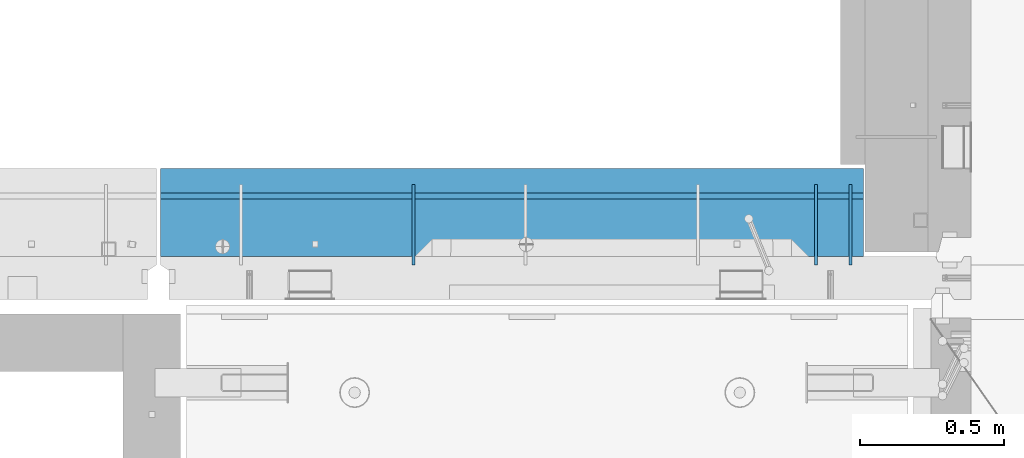
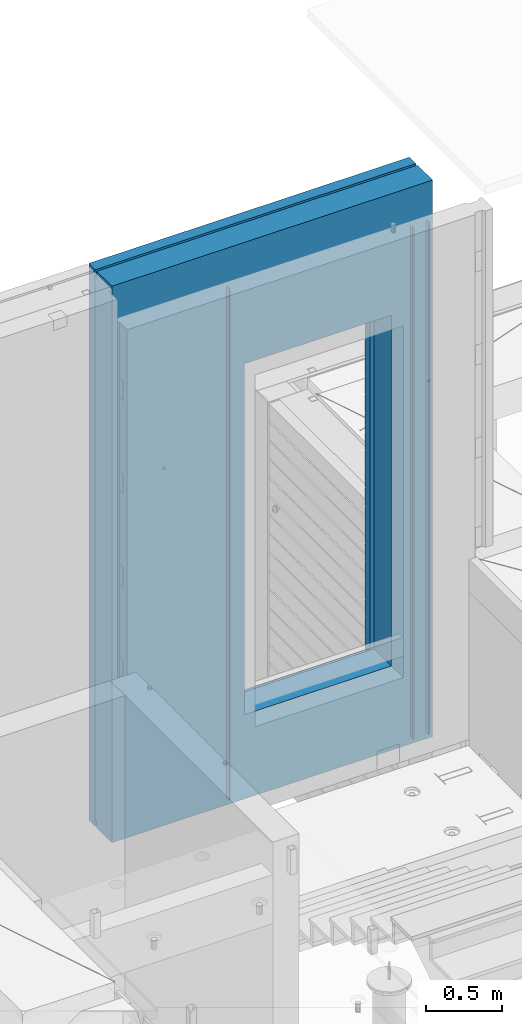
# One storey, part 240 of 352: 5 walls, 2 elements without a shape of their own.
"""IFC2X3 building model written with IfcOpenShell, lengths in millimetres."""

from ifc_helpers import new_model, si_unit, frame, origin_with_axes, place, context, subcontext, project, spatial, faceted_brep, material, type_object, element, aggregate, save


model = new_model("IFC2X3")

# Units and contexts
model_context = context("Model", 3, precision=1e-05, world=origin_with_axes())
body_context = subcontext(model_context, "Body", "Model", "MODEL_VIEW")
ifc_project = project(units=[si_unit("LENGTHUNIT", "METRE", prefix="MILLI"), si_unit("AREAUNIT", "SQUARE_METRE"), si_unit("VOLUMEUNIT", "CUBIC_METRE"), si_unit("MASSUNIT", "GRAM", prefix="KILO"), si_unit("TIMEUNIT", "SECOND"), si_unit("PLANEANGLEUNIT", "RADIAN"), si_unit("SOLIDANGLEUNIT", "STERADIAN"), si_unit("THERMODYNAMICTEMPERATUREUNIT", "DEGREE_CELSIUS"), si_unit("LUMINOUSINTENSITYUNIT", "LUMEN")], contexts=[model_context])

# Site, building, storey
site_placement = place(None, origin_with_axes())
site = spatial("IfcSite", under=ifc_project, at=site_placement, CompositionType="ELEMENT")
building_placement = place(site_placement, origin_with_axes())
building = spatial("IfcBuilding", under=site, at=building_placement, CompositionType="ELEMENT")
storey_placement = place(building_placement, origin_with_axes())
storey = spatial("IfcBuildingStorey", under=building, at=storey_placement, Name="6", CompositionType="ELEMENT", Elevation=0.0)

# Assemblies, walls
assembly_1_placement = place(storey_placement, origin_with_axes())
assembly_1 = element("IfcElementAssembly", 1, at=assembly_1_placement, inside=storey, AssemblyPlace="NOTDEFINED", PredefinedType="REINFORCEMENT_UNIT")
ifc_material_1 = material(Name="Undefined")
wall_type_1 = type_object("IfcWallType", PredefinedType="NOTDEFINED")
wall_1_placement = place(assembly_1_placement, frame((21990.0002441406, 20550.0, 100370.0), z_axis=(0.0, 0.0, 1.0), x_axis=(0.0, 1.0, 0.0)))
wall_1 = element("IfcWall", 2, at=wall_1_placement, type_object=wall_type_1, material=ifc_material_1, Name="(PD)", context=body_context, shape_type="Brep", body=[
    faceted_brep([(0.0, 5.0, -2060.0), (0.0, 5.0, 2060.0), (280.0, 5.0, 2060.0), (280.0, 5.0, -2060.0), (0.0, -5.0, 2060.0), (280.0, -5.0, 2060.0), (0.0, -5.0, -2060.0), (280.0, -5.0, -2060.0)], [[[0, 1, 2, 3]], [[1, 4, 5, 2]], [[4, 6, 7, 5]], [[6, 0, 3, 7]], [[5, 7, 3, 2]], [[6, 4, 1, 0]]]),
])
wall_2_placement = place(assembly_1_placement, frame((20470.0002441406, 20550.0, 100370.0), z_axis=(0.0, 0.0, 1.0), x_axis=(0.0, 1.0, 0.0)))
wall_2 = element("IfcWall", 3, at=wall_2_placement, type_object=wall_type_1, material=ifc_material_1, Name="(PD)", context=body_context, shape_type="Brep", body=[
    faceted_brep([(0.0, 5.0, -2060.0), (0.0, 5.0, 2060.0), (280.0, 5.0, 2060.0), (280.0, 5.0, -2060.0), (0.0, -5.0, 2060.0), (280.0, -5.0, 2060.0), (0.0, -5.0, -2060.0), (280.0, -5.0, -2060.0)], [[[0, 1, 2, 3]], [[1, 4, 5, 2]], [[4, 6, 7, 5]], [[6, 0, 3, 7]], [[5, 7, 3, 2]], [[6, 4, 1, 0]]]),
])
wall_3_placement = place(assembly_1_placement, frame((21870.0002441406, 20550.0, 100370.0), z_axis=(0.0, 0.0, 1.0), x_axis=(0.0, 1.0, 0.0)))
wall_3 = element("IfcWall", 4, at=wall_3_placement, type_object=wall_type_1, material=ifc_material_1, Name="(PD)", context=body_context, shape_type="Brep", body=[
    faceted_brep([(0.0, 5.0, -2060.0), (0.0, 5.0, 2060.0), (280.0, 5.0, 2060.0), (280.0, 5.0, -2060.0), (0.0, -5.0, 2060.0), (280.0, -5.0, 2060.0), (0.0, -5.0, -2060.0), (280.0, -5.0, -2060.0)], [[[0, 1, 2, 3]], [[1, 4, 5, 2]], [[4, 6, 7, 5]], [[6, 0, 3, 7]], [[5, 7, 3, 2]], [[6, 4, 1, 0]]]),
])
ifc_material_2 = material(Name="CONCRETE/C30/37")
wall_type_2 = type_object("IfcWallType", PredefinedType="NOTDEFINED")
wall_4_placement = place(assembly_1_placement, frame((19590.0, 20842.5, 100497.5), z_axis=(0.0, 0.0, 1.0), x_axis=(1.0, 0.0, 0.0)))
wall_4 = element("IfcWall", 5, at=wall_4_placement, type_object=wall_type_2, material=ifc_material_2, context=body_context, shape_type="Brep", body=[
    faceted_brep([(2445.0, 32.4999992499361, 2094.99999999923), (3.63797880709171e-12, 32.4999992499361, 2094.99999999923), (3.63797880709171e-12, 32.4999991119403, 2105.00000040044), (2445.0, 32.4999991119403, 2105.00000040044), (2445.0, 42.4999996032966, 2092.99999994476), (0.0, 42.5, 2092.99999994476), (2445.0, 42.4999992424127, 1956.99999988925), (0.0, 42.5, 1956.99999988925), (2445.0, 32.4999991119403, 1955.00000040044), (0.0, 32.4999991119403, 1955.00000040044), (2445.0, 32.4999992499361, 1944.99999999923), (0.0, 32.4999992499361, 1944.99999999923), (2445.0, 42.4999994789941, 1942.99999994476), (0.0, 42.5, 1942.99999994476), (2445.0, 42.4999992424127, 1806.99999988925), (0.0, 42.5, 1806.99999988925), (2445.0, 32.4999991119403, 1805.00000040044), (0.0, 32.4999991119403, 1805.00000040044), (2445.0, 32.4999992499361, 1794.99999999923), (0.0, 32.4999992499361, 1794.99999999923), (2445.0, 42.4999994183854, 1792.99999994476), (0.0, 42.5, 1792.99999994476), (2445.0, 42.4999992424127, 1656.99999988925), (0.0, 42.5, 1656.99999988925), (2445.0, 32.4999991119403, 1655.00000040044), (0.0, 32.4999991119403, 1655.00000040044), (2445.0, 32.4999992499361, 1644.99999999923), (0.0, 32.4999992499361, 1644.99999999923), (2445.0, 42.4999993824968, 1642.99999994476), (0.0, 42.5, 1642.99999994476), (2445.0, 42.4999992424127, 1506.99999988925), (0.0, 42.5, 1506.99999988925), (2445.0, 32.4999991119403, 1505.00000040044), (0.0, 32.4999991119403, 1505.00000040044), (2445.0, 32.4999992499361, 1494.99999999923), (0.0, 32.4999992499361, 1494.99999999923), (2445.0, 42.4999993587662, 1492.99999994476), (0.0, 42.5, 1492.99999994476), (2445.0, 42.4999992424127, 1356.99999988925), (0.0, 42.5, 1356.99999988925), (2445.0, 32.4999991119403, 1355.00000040044), (-3.63797880709171e-12, 32.4999991127006, 1355.00000040044), (2445.0, 32.4999992499361, 1344.99999999923), (-3.63797880709171e-12, 32.4999992507037, 1344.99999999926), (2445.0, 42.4999993419115, 1342.99999994476), (0.0, 42.5, 1342.99999994476), (2445.0, 32.4999991119403, 1205.00000040044), (2445.0, 32.4999992499361, 1194.99999999923), (2103.82193430323, 32.4999992499361, 1194.99999999923), (2103.82193428699, 32.4999991119403, 1205.00000040044), (2445.0, 42.4999993293241, 1192.99999994476), (2104.99840497971, 42.4999994225873, 1192.99999994476), (2445.0, 42.4999992424127, 1056.99999988925), (2104.99840497971, 42.4999993477613, 1056.99999988925), (2445.0, 32.4999991119403, 1055.00000040044), (2103.82193428699, 32.4999991119403, 1055.00000040044), (2445.0, 32.4999992499361, 1044.99999999923), (2103.82193430323, 32.4999992499361, 1044.99999999923), (2445.0, 42.4999993195597, 1042.99999994476), (2104.99840497971, 42.4999994141799, 1042.99999994476), (2445.0, 42.4999992424127, 906.999999889245), (2104.99840497971, 42.4999993477613, 906.999999889245), (2445.0, 32.4999991119403, 905.00000040044), (2103.82193428699, 32.4999991119403, 905.00000040044), (2445.0, 32.4999992499361, 894.999999999229), (2103.82193430323, 32.4999992499361, 894.999999999229), (2445.0, 42.4999993117708, 892.999999944761), (2104.99840497971, 42.4999994074751, 892.999999944761), (2445.0, 42.4999992424127, 756.999999889245), (2104.99840497971, 42.4999993477613, 756.999999889245), (2445.0, 32.4999991119403, 755.00000040044), (2103.82193428699, 32.4999991119403, 755.00000040044), (2445.0, 32.4999992499361, 744.999999999229), (2103.82193430323, 32.4999992499361, 744.999999999229), (2445.0, 42.4999993054116, 742.999999944761), (2104.99840497971, 42.499999402, 742.999999944761), (2445.0, 42.4999992424127, 606.999999889245), (2104.99840497971, 42.4999993477613, 606.999999889245), (2445.0, 32.4999991119403, 605.00000040044), (2103.82193428699, 32.4999991119403, 605.00000040044), (2445.0, 32.4999992499361, 594.999999999229), (2103.82193430323, 32.4999992499361, 594.999999999229), (2445.0, 42.4999993001293, 592.999999944761), (2104.99840497971, 42.4999993974525, 592.999999944761), (2445.0, 42.4999992424273, 456.99999988926), (2104.99840497971, 42.4999993477759, 456.99999988926), (2445.0, 32.4999991119548, 455.000000400454), (2103.82193428699, 32.4999991119548, 455.000000400454), (2445.0, 32.4999992499543, 444.999999999243), (2103.82193430323, 32.4999992499543, 444.999999999243), (2445.0, 42.4999992956691, 442.999999944775), (2104.99840497971, 42.4999993936144, 442.999999944775), (2445.0, 42.4999992424382, 306.999999889245), (2104.99840497971, 42.4999993477832, 306.999999889245), (2445.0, 32.4999991119694, 305.000000400425), (2103.821934287, 32.4999991119694, 305.000000400425), (2445.0, 32.4999992499725, 294.999999999258), (2103.82193430323, 32.4999992499725, 294.999999999258), (2445.0, 42.4999992918456, 292.999999944761), (2104.99840497971, 42.499999390322, 292.999999944761), (2445.0, 42.4999992424418, 156.999999889245), (2104.99840497971, 42.4999993477868, 156.999999889245), (2445.0, 32.499999111973, 155.000000400425), (2103.821934287, 32.499999111973, 155.000000400425), (2445.0, 32.4999992499797, 144.999999999243), (2103.82193430323, 32.4999992499797, 144.999999999243), (2445.0, 42.4999992885387, 142.999999944761), (2104.99840497971, 42.4999993874735, 142.999999944761), (2445.0, 42.4999992424528, 6.99999988923082), (2104.99840497971, 42.4999993477977, 6.99999988923082), (2445.0, 32.4999991119839, 5.0000004004105), (2103.821934287, 32.4999991119839, 5.0000004004105), (2445.0, 32.499999249987, -5.0000000007858), (2103.82193430323, 32.499999249987, -5.0000000007858), (2445.0, 42.4999992856538, -7.00000005525362), (2104.99840497971, 42.4999993849924, -7.00000005525362), (2445.0, 42.4999992424673, -143.000000110769), (2104.99840497971, 42.4999993478086, -143.000000110769), (2445.0, 32.4999991119985, -144.99999959959), (2103.821934287, 32.4999991119985, -144.99999959959), (2445.0, 32.4999992500016, -155.000000000786), (2103.82193430323, 32.4999992500016, -155.000000000786), (2445.0, 42.4999992831217, -157.000000055254), (2104.99840497971, 42.4999993828096, -157.000000055254), (2445.0, 42.4999992424891, -293.00000011074), (2104.99840497971, 42.4999993478268, -293.00000011074), (2445.0, 32.4999991120203, -294.99999959956), (2103.821934287, 32.4999991120203, -294.99999959956), (2445.0, 32.4999992500198, -305.000000000771), (2103.82193430324, 32.4999992500198, -305.000000000771), (2445.0, 42.4999992808625, -307.000000055225), (2104.99840497971, 42.4999993808669, -307.000000055225), (2445.0, 42.4999992425001, -443.000000110755), (2104.99840497971, 42.4999993478377, -443.000000110755), (2445.0, 32.4999991120312, -444.999999599575), (2103.821934287, 32.4999991120312, -444.999999599575), (2445.0, 32.4999992500307, -455.000000000786), (2103.82193430324, 32.4999992500307, -455.000000000786), (2445.0, 42.4999992788435, -457.000000055239), (2104.99840497971, 42.499999379128, -457.000000055239), (2445.0, 42.499999242511, -593.000000110755), (2104.99840497971, 42.4999993478486, -593.000000110755), (2445.0, 32.4999991120421, -594.999999599575), (2103.821934287, 32.4999991120421, -594.999999599575), (2445.0, 32.4999992500452, -605.000000000771), (2103.82193430324, 32.4999992500452, -605.000000000771), (2445.0, 42.4999992770245, -607.000000055239), (2104.99840497971, 42.49999937756, -607.000000055239), (2445.0, 42.4999992425182, -743.000000110755), (2104.99840497971, 42.4999993478523, -743.000000110755), (2445.0, 32.4999991120494, -744.999999599575), (2103.821934287, 32.4999991120494, -744.999999599575), (2445.0, 32.4999992500561, -755.000000000757), (2103.82193430324, 32.4999992500561, -755.000000000757), (2445.0, 42.4999992795674, -757.000000055239), (2104.99840497971, 42.4999993797501, -757.000000055239), (2445.0, 42.499999246902, -893.000000110784), (2104.99840497971, 42.4999993516285, -893.000000110784), (2445.0, 32.4999991164295, -894.99999959959), (2103.82193428752, 32.4999991164295, -894.99999959959), (2445.0, 32.4999992544326, -905.000000000771), (2103.82193430375, 32.4999992544326, -905.000000000771), (2445.0, 42.4999992775483, -907.000000055268), (2104.99840497971, 42.4999993780111, -907.000000055268), (2445.0, 42.4999992463527, -1043.00000011075), (2104.99840497971, 42.4999993511556, -1043.00000011075), (2445.0, 32.4999991158838, -1044.99999959957), (2103.82193428746, 32.4999991158838, -1044.99999959957), (2445.0, 32.4999992538942, -1055.00000000077), (2103.82193430369, 32.4999992538942, -1055.00000000077), (2445.0, 42.4999992756893, -1057.00000005524), (2104.99840497971, 42.4999993764104, -1057.00000005524), (2445.0, 42.4999992458361, -1193.00000011075), (2104.99840497971, 42.4999993507117, -1193.00000011075), (2445.0, 32.4999991153672, -1194.99999959956), (2103.8219342874, 32.4999991153672, -1194.99999959956), (2445.0, 32.4999992533631, -1205.00000000077), (2103.82193430363, 32.4999992533631, -1205.00000000077), (2445.0, 42.4999992739249, -1207.00000005524), (2104.99840497971, 42.4999993748934, -1207.00000005524), (2445.0, 42.4999992452977, -1343.00000011074), (2104.99840497971, 42.4999993502461, -1343.00000011074), (2445.0, 32.4999991148288, -1344.99999959956), (2103.82193428733, 32.4999991148288, -1344.99999959956), (2445.0, 32.4999992528392, -1355.00000000077), (2103.82193430357, 32.4999992528392, -1355.00000000077), (2445.0, 42.4999992722733, -1357.00000005522), (2104.99840497971, 42.4999993734709, -1357.00000005522), (2445.0, 42.4999992447774, -1493.00000011075), (2104.99840497971, 42.4999993497986, -1493.00000011075), (2445.0, 32.499999114305, -1494.99999959956), (2103.82193428727, 32.499999114305, -1494.99999959956), (2445.0, 32.4999992523044, -1505.00000000077), (2103.82193430351, 32.4999992523044, -1505.00000000077), (2445.0, 42.4999992706944, -1507.00000005524), (2104.99840497971, 42.4999993721103, -1507.00000005524), (0.0, -42.5, -2242.5), (0.0, 42.5, -2242.5), (2445.0, 42.5, -2242.5), (2445.0, -42.5, -2242.5), (0.0, 42.5, -2107.00000005524), (2445.0, 42.5, -2107.00000005524), (0.0, 32.4999992501653, -2105.00000000079), (2445.0, 32.4999992501653, -2105.00000000079), (0.0, 32.4999991121585, -2094.99999959957), (2445.0, 32.4999991121585, -2094.99999959957), (2445.0, 42.4999992426237, -2093.00000011075), (0.0, 42.5, -2093.00000011075), (0.0, 42.5, -1957.00000005522), (2445.0, 42.4999992663834, -1957.00000005522), (0.0, 32.4999992506928, -1955.00000000077), (2445.0, 32.4999992506928, -1955.00000000077), (0.0, 32.4999991126861, -1944.99999959956), (2445.0, 32.4999991126861, -1944.99999959956), (2445.0, 42.4999992431549, -1943.00000011074), (0.0, 42.5, -1943.00000011074), (0.0, 42.5, -1807.00000005525), (2445.0, 42.4999992677476, -1807.00000005525), (0.0, 32.4999992512385, -1805.00000000077), (2445.0, 32.4999992512385, -1805.00000000077), (0.0, 32.499999113239, -1794.99999959957), (2445.0, 32.499999113239, -1794.99999959957), (2445.0, 42.4999992437079, -1793.00000011077), (0.0, 42.5, -1793.00000011077), (0.0, 42.5, -1657.00000005522), (2445.0, 42.4999992691955, -1657.00000005522), (0.0, 32.4999992517696, -1655.00000000074), (2445.0, 32.4999992517696, -1655.00000000074), (0.0, 32.4999991137702, -1644.99999959955), (2445.0, 32.4999991137702, -1644.99999959955), (2445.0, 42.4999992442426, -1643.00000011074), (0.0, 42.5, -1643.00000011074), (0.0, 32.4999991127006, 1205.00000040044), (0.0, 42.5, 1206.99999988925), (1034.99840497971, 42.4999996793049, 1206.99999988925), (1036.17487567242, 32.4999991119403, 1205.00000040044), (0.0, 32.4999992507037, 1194.99999999926), (1036.17487565618, 32.4999992499361, 1194.99999999923), (0.0, 42.5, 1192.99999994476), (1034.99840497971, 42.4999997160958, 1192.99999994476), (0.0, 42.5, 1056.99999988925), (1034.99840497971, 42.4999996793049, 1056.99999988925), (0.0, 32.4999991127006, 1055.00000040044), (1036.17487567242, 32.4999991119403, 1055.00000040044), (0.0, 32.4999992507037, 1044.99999999926), (1036.17487565618, 32.4999992499361, 1044.99999999923), (0.0, 42.5, 1042.99999994476), (1034.99840497971, 42.4999997119594, 1042.99999994476), (0.0, 42.5, 906.999999889245), (1034.99840497971, 42.4999996793049, 906.999999889245), (0.0, 32.4999991127006, 905.00000040044), (1036.17487567242, 32.4999991119403, 905.00000040044), (0.0, 32.4999992507037, 894.999999999258), (1036.17487565618, 32.4999992499361, 894.999999999229), (0.0, 42.5, 892.999999944761), (1034.99840497971, 42.4999997086634, 892.999999944761), (0.0, 42.5, 756.999999889245), (1034.99840497971, 42.4999996793049, 756.999999889245), (0.0, 32.4999991127006, 755.00000040044), (1036.17487567242, 32.4999991119403, 755.00000040044), (0.0, 32.4999992507037, 744.999999999258), (1036.17487565618, 32.4999992499361, 744.999999999229), (0.0, 42.5, 742.999999944761), (1034.99840497971, 42.4999997059713, 742.999999944761), (0.0, 42.5, 606.999999889245), (1034.99840497971, 42.4999996793049, 606.999999889245), (3.63797880709171e-12, 32.4999991127006, 605.00000040044), (1036.17487567242, 32.4999991119403, 605.00000040044), (3.63797880709171e-12, 32.4999992507037, 594.999999999258), (1036.17487565618, 32.4999992499361, 594.999999999229), (0.0, 42.5, 592.999999944761), (1034.99840497971, 42.4999997037376, 592.999999944761), (0.0, 42.5, 456.999999889245), (1034.99840497971, 42.4999996793122, 456.99999988926), (0.0, 32.4999991127006, 455.00000040044), (1036.17487567242, 32.4999991119548, 455.000000400454), (0.0, 32.4999992507037, 444.999999999258), (1036.17487565618, 32.4999992499543, 444.999999999243), (0.0, 42.5, 442.999999944761), (1034.99840497971, 42.4999997018494, 442.999999944775), (0.0, 42.5, 306.999999889245), (1034.99840497971, 42.4999996793158, 306.999999889245), (-3.63797880709171e-12, 32.4999991127006, 305.00000040044), (1036.17487567241, 32.4999991119694, 305.000000400425), (-3.63797880709171e-12, 32.4999992507037, 294.999999999258), (1036.17487565618, 32.4999992499725, 294.999999999258), (0.0, 42.5, 292.999999944761), (1034.99840497971, 42.4999997002305, 292.999999944761), (0.0, 42.5, 156.999999889245), (1034.99840497971, 42.4999996793158, 156.999999889245), (-3.63797880709171e-12, 32.4999991127006, 155.00000040044), (1036.17487567241, 32.499999111973, 155.000000400425), (-3.63797880709171e-12, 32.4999992507037, 144.999999999258), (1036.17487565618, 32.4999992499797, 144.999999999243), (0.0, 42.5, 142.999999944761), (1034.99840497971, 42.4999996988299, 142.999999944761), (0.0, 42.5, 6.99999988924537), (1034.99840497971, 42.4999996793194, 6.99999988923082), (0.0, 32.4999991127006, 5.0000004004396), (1036.17487567241, 32.4999991119839, 5.0000004004105), (0.0, 32.4999992507037, -5.00000000074215), (1036.17487565617, 32.499999249987, -5.0000000007858), (0.0, 42.5, -7.00000005523907), (1034.99840497971, 42.4999996976076, -7.00000005525362), (0.0, 42.5, -143.000000110755), (1034.99840497971, 42.4999996793267, -143.000000110769), (3.63797880709171e-12, 32.4999991127006, -144.99999959956), (1036.17487567241, 32.4999991119985, -144.99999959959), (3.63797880709171e-12, 32.4999992507037, -155.000000000742), (1036.17487565617, 32.4999992500016, -155.000000000786), (0.0, 42.5, -157.000000055239), (1034.99840497971, 42.4999996965344, -157.000000055254), (0.0, 42.5, -293.000000110755), (1034.99840497971, 42.499999679334, -293.00000011074), (0.0, 32.4999991127006, -294.99999959956), (1036.1748756724, 32.4999991120203, -294.99999959956), (0.0, 32.4999992507037, -305.000000000742), (1036.17487565617, 32.4999992500198, -305.000000000771), (0.0, 42.5, -307.000000055239), (1034.99840497971, 42.4999996955812, -307.000000055225), (0.0, 42.5, -443.000000110755), (1034.99840497971, 42.4999996793413, -443.000000110755), (0.0, 32.4999991127006, -444.99999959956), (1036.1748756724, 32.4999991120312, -444.999999599575), (0.0, 32.4999992507037, -455.000000000742), (1036.17487565617, 32.4999992500307, -455.000000000786), (0.0, 42.5, -457.000000055239), (1034.99840497971, 42.4999996947263, -457.000000055239), (0.0, 42.5, -593.000000110755), (1034.99840497971, 42.4999996793449, -593.000000110755), (3.63797880709171e-12, 32.4999991127006, -594.99999959956), (1036.1748756724, 32.4999991120421, -594.999999599575), (3.63797880709171e-12, 32.4999992507037, -605.000000000742), (1036.17487565617, 32.4999992500452, -605.000000000771), (0.0, 42.5, -607.000000055239), (1034.99840497971, 42.499999693955, -607.000000055239), (0.0, 42.5, -743.000000110755), (1034.99840497971, 42.4999996793485, -743.000000110755), (0.0, 32.4999991127006, -744.99999959956), (1036.1748756724, 32.4999991120494, -744.999999599575), (0.0, 32.4999992507037, -755.000000000742), (1036.17487565616, 32.4999992500561, -755.000000000757), (0.0, 42.5, -757.000000055239), (1034.99840497971, 42.4999996950319, -757.000000055239), (0.0, 42.5, -893.000000110755), (1034.99840497971, 42.4999996812039, -893.000000110784), (0.0, 32.4999991127006, -894.99999959956), (1036.17487567189, 32.4999991164295, -894.99999959959), (0.0, 32.4999992507037, -905.000000000742), (1036.17487565565, 32.4999992544326, -905.000000000771), (0.0, 42.5, -907.000000055239), (1034.99840497971, 42.499999694177, -907.000000055268), (0.0, 42.5, -1043.00000011075), (1034.99840497971, 42.4999996809711, -1043.00000011075), (0.0, 32.4999991127006, -1044.99999959956), (1036.17487567195, 32.4999991158838, -1044.99999959957), (0.0, 32.4999992507037, -1055.00000000074), (1036.17487565571, 32.4999992538942, -1055.00000000077), (0.0, 42.5, -1057.00000005524), (1034.99840497971, 42.4999996933911, -1057.00000005524), (0.0, 42.5, -1193.00000011075), (1034.99840497971, 42.4999996807528, -1193.00000011075), (0.0, 32.4999991127006, -1194.99999959956), (1036.17487567201, 32.4999991153672, -1194.99999959956), (0.0, 32.4999992507037, -1205.00000000074), (1036.17487565578, 32.4999992533631, -1205.00000000077), (0.0, 42.5, -1207.00000005524), (1034.99840497971, 42.4999996926454, -1207.00000005524), (0.0, 42.5, -1343.00000011075), (1034.99840497971, 42.4999996805236, -1343.00000011074), (0.0, 32.4999991127006, -1344.99999959956), (1036.17487567207, 32.4999991148288, -1344.99999959956), (0.0, 32.4999992507037, -1355.00000000074), (1036.17487565584, 32.4999992528392, -1355.00000000077), (0.0, 42.5, -1357.00000005524), (1034.99840497971, 42.4999996919432, -1357.00000005522), (0.0, 42.5, -1493.00000011075), (1034.99840497971, 42.4999996803053, -1493.00000011075), (3.63797880709171e-12, 32.499999114305, -1494.99999959956), (1036.17487567214, 32.499999114305, -1494.99999959956), (3.63797880709171e-12, 32.4999992523044, -1505.00000000077), (1036.1748756559, 32.4999992523044, -1505.00000000077), (0.0, 42.5, -1507.00000005524), (1034.99840497971, 42.4999996912738, -1507.00000005524), (1034.99840497971, 42.5, -1607.5), (2104.99840497971, 42.5, -1607.5), (1044.99840497971, -42.5, -1557.5), (2094.99840497971, -42.5, -1557.5), (0.0, -42.5, 2242.5), (2445.0, -42.5, 2242.5), (1044.99840497971, -42.5, 1232.5), (1044.99840497971, -42.5, 1237.5), (2094.99840497971, -42.5, 1237.5), (2094.99840497971, -42.5, 1232.5), (0.0, 42.5, 2242.5), (2445.0, 42.5, 2242.5), (2445.0, 42.4999992424127, 2106.99999988925), (0.0, 42.5, 2106.99999988925), (2445.0, 42.4999992424127, 1206.99999988925), (1044.99840497971, 42.5, 1232.5), (1034.99840497971, 42.5, 1232.5), (2104.99840497971, 42.4999993477613, 1206.99999988925), (2104.99840497971, 42.5, 1232.5), (2094.99840497971, 42.5, 1232.5)], [[[0, 1, 2, 3]], [[4, 5, 1, 0]], [[6, 7, 5, 4]], [[6, 8, 9, 7]], [[10, 11, 9, 8]], [[12, 13, 11, 10]], [[14, 15, 13, 12]], [[14, 16, 17, 15]], [[18, 19, 17, 16]], [[20, 21, 19, 18]], [[22, 23, 21, 20]], [[22, 24, 25, 23]], [[26, 27, 25, 24]], [[28, 29, 27, 26]], [[30, 31, 29, 28]], [[30, 32, 33, 31]], [[34, 35, 33, 32]], [[36, 37, 35, 34]], [[38, 39, 37, 36]], [[38, 40, 41, 39]], [[42, 43, 41, 40]], [[44, 45, 43, 42]], [[46, 47, 48, 49]], [[47, 50, 51, 48]], [[50, 52, 53, 51]], [[52, 54, 55, 53]], [[54, 56, 57, 55]], [[56, 58, 59, 57]], [[58, 60, 61, 59]], [[60, 62, 63, 61]], [[62, 64, 65, 63]], [[64, 66, 67, 65]], [[66, 68, 69, 67]], [[68, 70, 71, 69]], [[70, 72, 73, 71]], [[72, 74, 75, 73]], [[74, 76, 77, 75]], [[76, 78, 79, 77]], [[78, 80, 81, 79]], [[80, 82, 83, 81]], [[82, 84, 85, 83]], [[84, 86, 87, 85]], [[86, 88, 89, 87]], [[88, 90, 91, 89]], [[90, 92, 93, 91]], [[92, 94, 95, 93]], [[94, 96, 97, 95]], [[96, 98, 99, 97]], [[98, 100, 101, 99]], [[100, 102, 103, 101]], [[102, 104, 105, 103]], [[104, 106, 107, 105]], [[106, 108, 109, 107]], [[108, 110, 111, 109]], [[110, 112, 113, 111]], [[112, 114, 115, 113]], [[114, 116, 117, 115]], [[116, 118, 119, 117]], [[118, 120, 121, 119]], [[120, 122, 123, 121]], [[122, 124, 125, 123]], [[124, 126, 127, 125]], [[126, 128, 129, 127]], [[128, 130, 131, 129]], [[130, 132, 133, 131]], [[132, 134, 135, 133]], [[134, 136, 137, 135]], [[136, 138, 139, 137]], [[138, 140, 141, 139]], [[140, 142, 143, 141]], [[142, 144, 145, 143]], [[144, 146, 147, 145]], [[146, 148, 149, 147]], [[148, 150, 151, 149]], [[150, 152, 153, 151]], [[152, 154, 155, 153]], [[154, 156, 157, 155]], [[156, 158, 159, 157]], [[158, 160, 161, 159]], [[160, 162, 163, 161]], [[162, 164, 165, 163]], [[164, 166, 167, 165]], [[166, 168, 169, 167]], [[168, 170, 171, 169]], [[170, 172, 173, 171]], [[172, 174, 175, 173]], [[174, 176, 177, 175]], [[176, 178, 179, 177]], [[178, 180, 181, 179]], [[180, 182, 183, 181]], [[182, 184, 185, 183]], [[184, 186, 187, 185]], [[186, 188, 189, 187]], [[188, 190, 191, 189]], [[190, 192, 193, 191]], [[192, 194, 195, 193]], [[196, 197, 198, 199]], [[198, 197, 200, 201]], [[201, 200, 202, 203]], [[203, 202, 204, 205]], [[206, 205, 204, 207]], [[206, 207, 208, 209]], [[209, 208, 210, 211]], [[211, 210, 212, 213]], [[214, 213, 212, 215]], [[214, 215, 216, 217]], [[217, 216, 218, 219]], [[219, 218, 220, 221]], [[222, 221, 220, 223]], [[222, 223, 224, 225]], [[225, 224, 226, 227]], [[227, 226, 228, 229]], [[230, 229, 228, 231]], [[232, 233, 234, 235]], [[236, 232, 235, 237]], [[238, 236, 237, 239]], [[240, 238, 239, 241]], [[242, 240, 241, 243]], [[244, 242, 243, 245]], [[246, 244, 245, 247]], [[248, 246, 247, 249]], [[250, 248, 249, 251]], [[252, 250, 251, 253]], [[254, 252, 253, 255]], [[256, 254, 255, 257]], [[258, 256, 257, 259]], [[260, 258, 259, 261]], [[262, 260, 261, 263]], [[264, 262, 263, 265]], [[266, 264, 265, 267]], [[268, 266, 267, 269]], [[270, 268, 269, 271]], [[272, 270, 271, 273]], [[274, 272, 273, 275]], [[276, 274, 275, 277]], [[278, 276, 277, 279]], [[280, 278, 279, 281]], [[282, 280, 281, 283]], [[284, 282, 283, 285]], [[286, 284, 285, 287]], [[288, 286, 287, 289]], [[290, 288, 289, 291]], [[292, 290, 291, 293]], [[294, 292, 293, 295]], [[296, 294, 295, 297]], [[298, 296, 297, 299]], [[300, 298, 299, 301]], [[302, 300, 301, 303]], [[304, 302, 303, 305]], [[306, 304, 305, 307]], [[308, 306, 307, 309]], [[310, 308, 309, 311]], [[312, 310, 311, 313]], [[314, 312, 313, 315]], [[316, 314, 315, 317]], [[318, 316, 317, 319]], [[320, 318, 319, 321]], [[322, 320, 321, 323]], [[324, 322, 323, 325]], [[326, 324, 325, 327]], [[328, 326, 327, 329]], [[330, 328, 329, 331]], [[332, 330, 331, 333]], [[334, 332, 333, 335]], [[336, 334, 335, 337]], [[338, 336, 337, 339]], [[340, 338, 339, 341]], [[342, 340, 341, 343]], [[344, 342, 343, 345]], [[346, 344, 345, 347]], [[348, 346, 347, 349]], [[350, 348, 349, 351]], [[352, 350, 351, 353]], [[354, 352, 353, 355]], [[356, 354, 355, 357]], [[358, 356, 357, 359]], [[360, 358, 359, 361]], [[362, 360, 361, 363]], [[364, 362, 363, 365]], [[366, 364, 365, 367]], [[368, 366, 367, 369]], [[370, 368, 369, 371]], [[372, 370, 371, 373]], [[374, 372, 373, 375]], [[376, 374, 375, 377]], [[378, 376, 377, 379]], [[380, 378, 379, 381]], [[382, 380, 381, 383]], [[194, 230, 231, 382, 383, 384, 385, 195]], [[384, 386, 387, 385]], [[388, 196, 199, 389], [387, 386, 390, 391, 392, 393]], [[394, 388, 389, 395]], [[394, 395, 396, 397]], [[1, 5, 7, 9, 11, 13, 15, 17, 19, 21, 23, 25, 27, 29, 31, 33, 35, 37, 39, 41, 43, 45, 233, 232, 236, 238, 240, 242, 244, 246, 248, 250, 252, 254, 256, 258, 260, 262, 264, 266, 268, 270, 272, 274, 276, 278, 280, 282, 284, 286, 288, 290, 292, 294, 296, 298, 300, 302, 304, 306, 308, 310, 312, 314, 316, 318, 320, 322, 324, 326, 328, 330, 332, 334, 336, 338, 340, 342, 344, 346, 348, 350, 352, 354, 356, 358, 360, 362, 364, 366, 368, 370, 372, 374, 376, 378, 380, 382, 231, 228, 226, 224, 223, 220, 218, 216, 215, 212, 210, 208, 207, 204, 202, 200, 197, 196, 388, 394, 397, 2]], [[396, 3, 2, 397]], [[395, 389, 199, 198, 201, 203, 205, 206, 209, 211, 213, 214, 217, 219, 221, 222, 225, 227, 229, 230, 194, 192, 190, 188, 186, 184, 182, 180, 178, 176, 174, 172, 170, 168, 166, 164, 162, 160, 158, 156, 154, 152, 150, 148, 146, 144, 142, 140, 138, 136, 134, 132, 130, 128, 126, 124, 122, 120, 118, 116, 114, 112, 110, 108, 106, 104, 102, 100, 98, 96, 94, 92, 90, 88, 86, 84, 82, 80, 78, 76, 74, 72, 70, 68, 66, 64, 62, 60, 58, 56, 54, 52, 50, 47, 46, 398, 44, 42, 40, 38, 36, 34, 32, 30, 28, 26, 24, 22, 20, 18, 16, 14, 12, 10, 8, 6, 4, 0, 3, 396]], [[399, 400, 234, 233, 45, 44, 398, 401, 402, 403]], [[390, 386, 384, 383, 381, 379, 377, 375, 373, 371, 369, 367, 365, 363, 361, 359, 357, 355, 353, 351, 349, 347, 345, 343, 341, 339, 337, 335, 333, 331, 329, 327, 325, 323, 321, 319, 317, 315, 313, 311, 309, 307, 305, 303, 301, 299, 297, 295, 293, 291, 289, 287, 285, 283, 281, 279, 277, 275, 273, 271, 269, 267, 265, 263, 261, 259, 257, 255, 253, 251, 249, 247, 245, 243, 241, 239, 237, 235, 234, 400, 391]], [[399, 403, 402, 392, 391, 400]], [[401, 49, 48, 51, 53, 55, 57, 59, 61, 63, 65, 67, 69, 71, 73, 75, 77, 79, 81, 83, 85, 87, 89, 91, 93, 95, 97, 99, 101, 103, 105, 107, 109, 111, 113, 115, 117, 119, 121, 123, 125, 127, 129, 131, 133, 135, 137, 139, 141, 143, 145, 147, 149, 151, 153, 155, 157, 159, 161, 163, 165, 167, 169, 171, 173, 175, 177, 179, 181, 183, 185, 187, 189, 191, 193, 195, 385, 387, 393, 392, 402]], [[398, 46, 49, 401]]]),
])
assembly_2_placement = place(assembly_1_placement, origin_with_axes())
assembly_2 = element("IfcElementAssembly", 6, at=assembly_2_placement, Name="Steel Assembly", AssemblyPlace="NOTDEFINED", PredefinedType="NOTDEFINED")
aggregate(assembly_1, [wall_1, wall_4, assembly_2, wall_2, wall_3])
ifc_material_3 = material(Name="COS5gt")
wall_type_3 = type_object("IfcWallType", PredefinedType="NOTDEFINED")
wall_5_placement = place(assembly_2_placement, frame((19590.0, 20690.0, 100497.5), z_axis=(0.0, 0.0, 1.0), x_axis=(1.0, 0.0, 0.0)))
wall_5 = element("IfcWall", 7, at=wall_5_placement, type_object=wall_type_3, material=ifc_material_3, context=body_context, shape_type="Brep", body=[
    faceted_brep([(2445.0, 90.0, 2242.5), (2445.0, 90.0, 2192.74000000001), (0.0, 90.0, 2192.74000000001), (0.0, 90.0, 2242.5), (2445.0, 110.0, 2192.74000000001), (0.0, 110.0, 2192.74000000001), (2445.0, 90.0, -2242.5), (0.0, 90.0, -2242.5), (0.0, 90.0, -2192.5), (2445.0, 90.0, -2192.5), (2445.0, -110.0, -2242.5), (0.0, -110.0, -2242.5), (0.0, -110.0, 2242.5), (2445.0, -110.0, 2242.5), (0.0, 110.0, -2192.5), (2445.0, 110.0, -2192.5), (1009.05245909535, -110.0, -1563.44594588435), (1009.05245909535, -110.0, 1263.44594588435), (2130.94435086406, -110.0, 1263.44594588435), (2130.94435086406, -110.0, -1563.44594588435), (1014.99840497971, 109.999997720999, -1552.5), (1014.99840497971, 109.999997720999, 1257.5), (1014.99840497971, 109.999997720999, -1557.5), (2124.99840497971, 109.999997720999, -1557.5), (2094.99840497971, 109.999997720999, -1557.5), (1044.99840497971, 109.999997720999, -1557.5), (2124.99840497971, 109.999997720999, 1257.5), (2124.99840497971, 109.999997720999, -1552.5)], [[[0, 1, 2, 3]], [[4, 5, 2, 1]], [[6, 7, 8, 9]], [[10, 11, 7, 6]], [[12, 13, 0, 3]], [[14, 8, 7, 11, 12, 3, 2, 5]], [[15, 9, 8, 14]], [[0, 13, 10, 6, 9, 15, 4, 1]], [[12, 11, 10, 13], [16, 17, 18, 19]], [[20, 21, 17, 16, 22]], [[19, 23, 24, 25, 22, 16]], [[18, 26, 27, 23, 19]], [[17, 21, 26, 18]], [[15, 14, 5, 4], [20, 22, 25, 24, 23, 27, 26, 21]]]),
])
aggregate(assembly_2, [wall_5])

save(model, "model.ifc")
